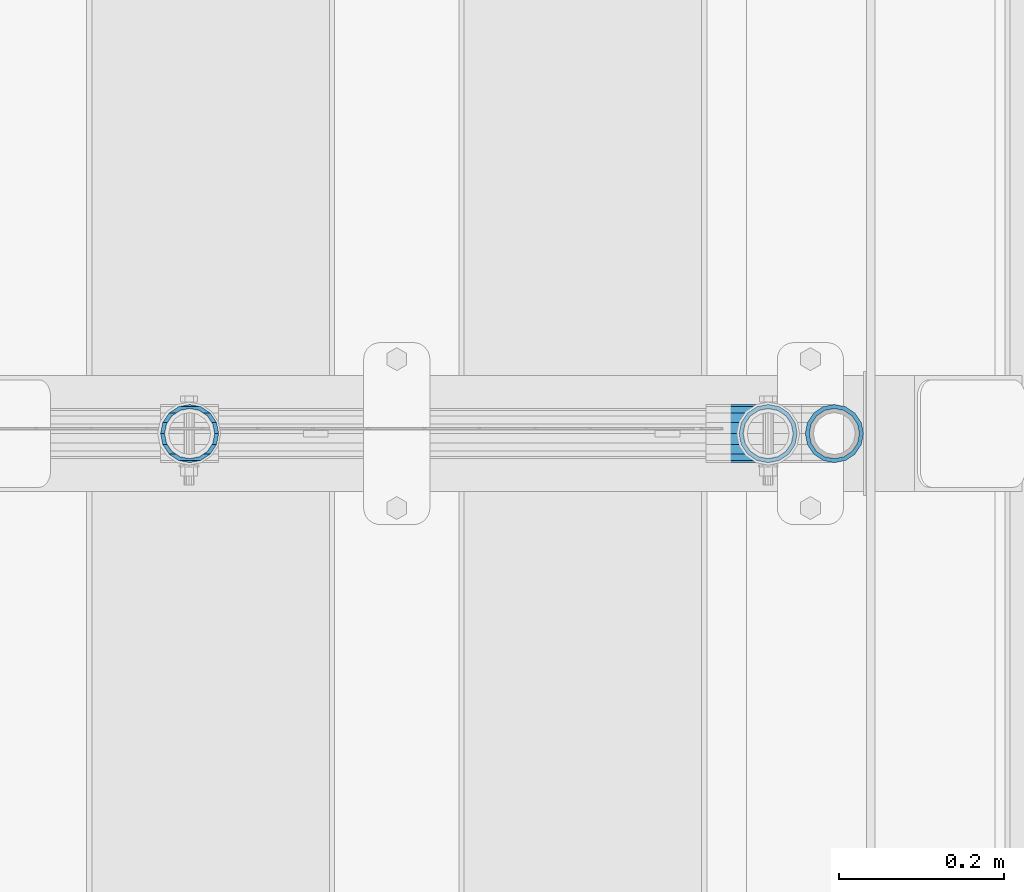
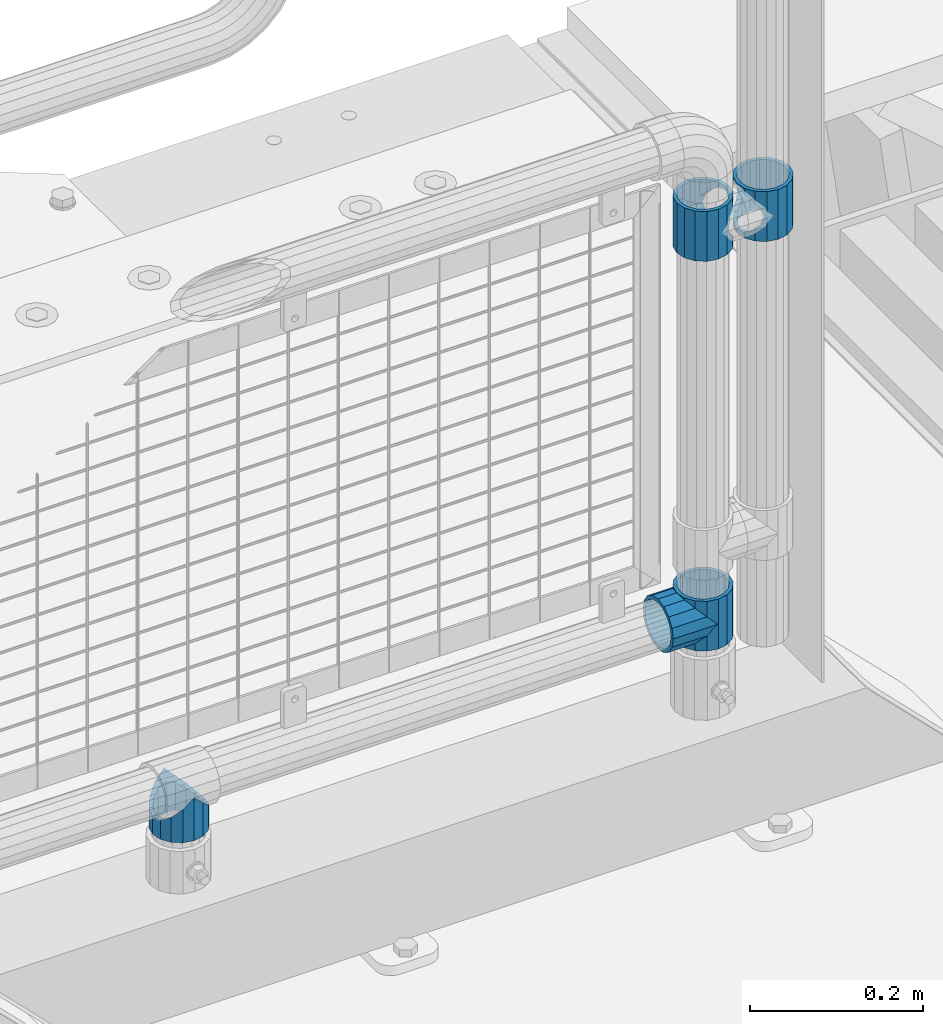
# One storey, part 188 of 270: 5 beams.
"""IFC2X3 building model written with IfcOpenShell, lengths in millimetres."""

import ifcopenshell
import ifcopenshell.guid

model = None  # the IFC model being written
_history = None  # IfcOwnerHistory: only IFC2X3 demands one
_inside = {}  # id of a spatial element -> (the spatial element, [elements in it])
_under = {}  # id of a project, library or spatial element -> (it, [spatial elements below it])
_declared = {}  # id of a project -> (the project, [libraries it declares])
_typed = {}  # id of a type object -> (the type object, [elements of that type])
_made_of = {}  # id of a material, layer set ... -> (it, [elements and type objects made of it])


def new_model(schema):
    """Start an empty IFC model of exactly this schema.

    Asked for "IFC4X3", IfcOpenShell would pick the latest addendum, in which some entities
    have other attributes; the version numbers below select the first issue.
    IFC2X3 requires an IfcOwnerHistory on every rooted entity: one is made here for all.
    """
    global model, _history
    if schema == "IFC4X3":
        model = ifcopenshell.file(schema_version=(4, 3, 0, 0))
    else:
        model = ifcopenshell.file(schema=schema)
    _inside.clear()
    _under.clear()
    _declared.clear()
    _typed.clear()
    _made_of.clear()
    _history = None
    if model.schema == "IFC2X3":
        org = make("IfcOrganization", Name="unknown")
        user = make(
            "IfcPersonAndOrganization",
            ThePerson=make("IfcPerson", FamilyName="unknown"),
            TheOrganization=org,
        )
        app = make(
            "IfcApplication",
            ApplicationDeveloper=org,
            Version="unknown",
            ApplicationFullName="unknown",
            ApplicationIdentifier="unknown",
        )
        _history = make(
            "IfcOwnerHistory",
            OwningUser=user,
            OwningApplication=app,
            ChangeAction="ADDED",
            CreationDate=0,
        )
    return model


def make(cls, **values):
    """One entity of the class cls with the attributes given. An attribute that is None is left unset."""
    return model.create_entity(
        cls, **{name: value for name, value in values.items() if value is not None}
    )


def rooted(cls, **values):
    """An entity with a GlobalId (a new one), such as an element, a storey or a relation."""
    return make(cls, GlobalId=ifcopenshell.guid.new(), OwnerHistory=_history, **values)


def si_unit(unit_type, name, prefix=None):
    """IfcSIUnit, for example si_unit("LENGTHUNIT", "METRE", prefix="MILLI")."""
    return make("IfcSIUnit", UnitType=unit_type, Prefix=prefix, Name=name)


def assignment(units):
    """IfcUnitAssignment: the units of a project."""
    return None if units is None else make("IfcUnitAssignment", Units=units)


def point(xyz):
    """IfcCartesianPoint."""
    return None if xyz is None else make("IfcCartesianPoint", Coordinates=xyz)


def direction(xyz):
    """IfcDirection."""
    return None if xyz is None else make("IfcDirection", DirectionRatios=xyz)


def frame(location, z_axis=None, x_axis=None):
    """IfcAxis2Placement3D, a coordinate frame: its origin and axes. An axis left out is left unset."""
    return make(
        "IfcAxis2Placement3D",
        Location=point(location),
        Axis=direction(z_axis),
        RefDirection=direction(x_axis),
    )


def origin_with_axes():
    """The frame at (0, 0, 0) with the z axis (0, 0, 1) and the x axis (1, 0, 0) written out."""
    return frame((0.0, 0.0, 0.0), z_axis=(0.0, 0.0, 1.0), x_axis=(1.0, 0.0, 0.0))


def place(relative_to, where):
    """IfcLocalPlacement: puts the frame where relative to a parent placement (None: the world)."""
    return make(
        "IfcLocalPlacement", PlacementRelTo=relative_to, RelativePlacement=where
    )


def context(
    kind, dimensions, precision=None, world=None, true_north=None, identifier=None
):
    """IfcGeometricRepresentationContext, for example the 3D "Model" context."""
    return make(
        "IfcGeometricRepresentationContext",
        ContextIdentifier=identifier,
        ContextType=kind,
        CoordinateSpaceDimension=dimensions,
        Precision=precision,
        WorldCoordinateSystem=world,
        TrueNorth=true_north,
    )


def subcontext(parent, identifier, kind, view, scale=None):
    """IfcGeometricRepresentationSubContext, for example "Body" below "Model"."""
    return make(
        "IfcGeometricRepresentationSubContext",
        ContextIdentifier=identifier,
        ContextType=kind,
        ParentContext=parent,
        TargetScale=scale,
        TargetView=view,
    )


def project(units=None, contexts=None):
    """IfcProject with its units and contexts."""
    return rooted(
        "IfcProject",
        Name="project",
        RepresentationContexts=contexts,
        UnitsInContext=assignment(units),
    )


def spatial(cls, under=None, at=None, **own):
    """A site, building, storey or space (cls), placed at a placement, below another one or the project."""
    s = rooted(cls, ObjectPlacement=at, **own)
    if under is not None:
        _under.setdefault(under.id(), (under, []))[1].append(s)
    return s


def faces_of(points, faces, orient=None, outer=None):
    """IfcFace entities. A face is a list of loops; a loop is a list of indices into points, from 0.

    orient and outer hold one flag for each loop. By default every Orientation is true, the
    first loop of a face is its IfcFaceOuterBound and the others are IfcFaceBound.
    """
    made = []
    for i, loops in enumerate(faces):
        bounds = []
        for j, loop in enumerate(loops):
            is_outer = j == 0 if outer is None else outer[i][j]
            bounds.append(
                make(
                    "IfcFaceOuterBound" if is_outer else "IfcFaceBound",
                    Bound=make("IfcPolyLoop", Polygon=[points[k] for k in loop]),
                    Orientation=True if orient is None else orient[i][j],
                )
            )
        made.append(make("IfcFace", Bounds=bounds))
    return made


def faceted_brep(points, faces, orient=None, outer=None, voids=None):
    """IfcFacetedBrep: a solid bounded by flat faces; with voids (closed shells), ...WithVoids."""
    shared = [point(p) for p in points]
    hull = make("IfcClosedShell", CfsFaces=faces_of(shared, faces, orient, outer))
    if voids is None:
        return make("IfcFacetedBrep", Outer=hull)
    return make(
        "IfcFacetedBrepWithVoids",
        Outer=hull,
        Voids=[
            make(cls, CfsFaces=faces_of(shared, fs, o, b)) for cls, fs, o, b in voids
        ],
    )


def shape(context_of_items, identifier, shape_type, items):
    """IfcShapeRepresentation: the items that make up one representation, for example the "Body"."""
    return make(
        "IfcShapeRepresentation",
        ContextOfItems=context_of_items,
        RepresentationIdentifier=identifier,
        RepresentationType=shape_type,
        Items=items,
    )


def material(Name=None, Category=None):
    """IfcMaterial."""
    return make("IfcMaterial", Name=Name, Category=Category)


def made_of(thing, what):
    """Note that an element or type object is made of a material, layer set ...; save() writes the relation."""
    if what is not None:
        _made_of.setdefault(what.id(), (what, []))[1].append(thing)
    return thing


def type_object(cls, material=None, **own):
    """A type object (cls), such as IfcWallType, which elements share."""
    return made_of(rooted(cls, **own), material)


def element(
    cls,
    number,
    at=None,
    inside=None,
    cuts=None,
    type_object=None,
    material=None,
    context=None,
    identifier="Body",
    shape_type=None,
    held_by="IfcProductDefinitionShape",
    body=None,
    shapes=None,
    **own,
):
    """One element of the class cls, such as IfcWall. Its Tag is "e" and its number.

    at: its placement. inside: the storey or other place that contains it. cuts: it is an
    opening in that element (IfcRelVoidsElement). A single representation is given by context,
    identifier, shape_type and body (its items); several are given by shapes. held_by: the class
    of the entity that holds the representations. save() writes the other relations.
    """
    e = rooted(cls, Tag="e%d" % number, ObjectPlacement=at, **own)
    if body is not None:
        shapes = [shape(context, identifier, shape_type, body)]
    if shapes is not None:
        e.Representation = make(held_by, Representations=shapes)
    if inside is not None:
        _inside.setdefault(inside.id(), (inside, []))[1].append(e)
    if cuts is not None:
        rooted(
            "IfcRelVoidsElement", RelatingBuildingElement=cuts, RelatedOpeningElement=e
        )
    if type_object is not None:
        _typed.setdefault(type_object.id(), (type_object, []))[1].append(e)
    return made_of(e, material)


def aggregate(whole, parts):
    """IfcRelAggregates: a whole, such as a stair, and the parts it consists of."""
    return rooted("IfcRelAggregates", RelatingObject=whole, RelatedObjects=parts)


def save(model, path):
    """Write the relations noted so far, then the file.

    IfcRelAggregates (storeys below a building ...), IfcRelContainedInSpatialStructure (elements
    in a storey), IfcRelDefinesByType, IfcRelAssociatesMaterial and IfcRelDeclares: one each for
    every whole, place, type object, material and project.
    """
    for whole, parts in _under.values():
        aggregate(whole, parts)
    for where, things in _inside.values():
        rooted(
            "IfcRelContainedInSpatialStructure",
            RelatedElements=things,
            RelatingStructure=where,
        )
    for kind, things in _typed.values():
        rooted("IfcRelDefinesByType", RelatedObjects=things, RelatingType=kind)
    for what, things in _made_of.values():
        rooted("IfcRelAssociatesMaterial", RelatedObjects=things, RelatingMaterial=what)
    for by, libraries in _declared.values():
        rooted("IfcRelDeclares", RelatingContext=by, RelatedDefinitions=libraries)
    model.write(path)


model = new_model("IFC2X3")

# Units and contexts
model_context = context("Model", 3, precision=1e-05, world=origin_with_axes())
body_context = subcontext(model_context, "Body", "Model", "MODEL_VIEW")
ifc_project = project(units=[si_unit("LENGTHUNIT", "METRE", prefix="MILLI"), si_unit("AREAUNIT", "SQUARE_METRE"), si_unit("VOLUMEUNIT", "CUBIC_METRE"), si_unit("MASSUNIT", "GRAM", prefix="KILO"), si_unit("TIMEUNIT", "SECOND"), si_unit("PLANEANGLEUNIT", "RADIAN"), si_unit("SOLIDANGLEUNIT", "STERADIAN"), si_unit("THERMODYNAMICTEMPERATUREUNIT", "DEGREE_CELSIUS"), si_unit("LUMINOUSINTENSITYUNIT", "LUMEN")], contexts=[model_context])

# Site, building, storey
site_placement = place(None, origin_with_axes())
site = spatial("IfcSite", under=ifc_project, at=site_placement, CompositionType="ELEMENT")
building_placement = place(site_placement, origin_with_axes())
building = spatial("IfcBuilding", under=site, at=building_placement, Name="Standard", CompositionType="ELEMENT")
storey_placement = place(building_placement, origin_with_axes())
storey = spatial("IfcBuildingStorey", under=building, at=storey_placement, Name="Undefined", CompositionType="ELEMENT", Elevation=0.0)

# Beams
ifc_material = material(Name="Misc_Undefined")
beam_type = type_object("IfcBeamType", PredefinedType="NOTDEFINED")
beam_1_placement = place(storey_placement, frame((19794.0, -16335.5, 883.82), z_axis=(-1.0, 0.0, 0.0), x_axis=(0.0, 0.0, -1.0)))
element("IfcBeam", 1, at=beam_1_placement, inside=storey, type_object=beam_type, material=ifc_material, context=body_context, shape_type="Brep", body=[
    faceted_brep([(7.11025618828319, -11.6144421722802, -32.8397438117172), (7.11025618828319, -11.6144421722802, -28.0397438117179), (13.689309190989, -21.4606908090118, -21.46069080901), (13.689309190989, -21.4606908090118, -27.1226768591041), (8.33762048232484, -13.4513226476338, -32.4743655677703), (23.5355578277203, -28.0397438117179, -11.614442172282), (23.5355578277203, -28.0397438117179, -20.0882031229885), (18.7689575919954, -24.8548033587067, -24.8548033587067), (35.1500000000015, -30.35, 0.0), (35.1500000000008, -30.3500000000004, -16.6306603983721), (46.7644421722812, -28.0397438117179, -11.614442172282), (46.7644421722812, -28.0397438117179, -20.0882031229885), (51.5310424080071, -24.8548033587067, -24.8548033587067), (56.6106908090125, -21.4606908090118, -21.46069080901), (56.6106908090125, -21.4606908090118, -27.1226768591041), (61.9623795176767, -13.4513226476338, -32.4743655677703), (63.1897438117183, -11.6144421722802, -28.0397438117179), (63.1897438117183, -11.6144421722802, -32.8397438117172), (65.5000000000008, 0.0, -30.3499999999985), (65.5000000000008, 0.0, -35.1500000000015), (63.1897438117183, 11.6144421722802, -28.0397438117179), (63.1897438117183, 11.6144421722802, -32.8397438117208), (56.6106908090125, 21.4606908090118, -21.46069080901), (56.6106908090125, 21.4606908090118, -27.1226768591005), (61.9623795176767, 13.4513226476338, -32.4743655677703), (46.7644421722812, 28.0397438117179, -11.614442172282), (46.7644421722812, 28.0397438117179, -20.0882031229812), (51.5310424080071, 24.8548033587067, -24.8548033587067), (35.1500000000015, 30.35, 0.0), (35.1500000000008, 30.3500000000004, -16.6306603983612), (23.5355578277203, 28.0397438117179, -11.614442172282), (23.5355578277203, 28.0397438117179, -20.0882031229812), (18.7689575919954, 24.8548033587067, -24.8548033587067), (13.689309190989, 21.4606908090118, -21.46069080901), (13.689309190989, 21.4606908090118, -27.1226768591005), (8.33762048232484, 13.4513226476338, -32.4743655677703), (7.11025618828324, 11.6144421722802, -28.0397438117179), (7.11025618828324, 11.6144421722802, -32.8397438117208), (4.80000000000075, 0.0, -30.3499999999985), (4.80000000000075, 0.0, -35.1500000000015), (0.0, 21.4606908090118, 21.46069080901), (0.0, 28.0397438117179, 11.614442172282), (70.2999999999993, 28.0397438117179, 11.614442172282), (70.2999999999993, 21.4606908090118, 21.46069080901), (0.0, 11.6144421722802, 28.0397438117179), (70.2999999999993, 11.6144421722802, 28.0397438117179), (0.0, 0.0, 30.3499999999985), (70.2999999999993, 0.0, 30.3499999999985), (0.0, -11.6144421722802, 28.0397438117179), (70.2999999999993, -11.6144421722802, 28.0397438117179), (0.0, -21.4606908090118, 21.46069080901), (70.2999999999993, -21.4606908090118, 21.46069080901), (0.0, -28.0397438117179, 11.614442172282), (70.2999999999993, -28.0397438117179, 11.614442172282), (0.0, -24.8548033587067, -24.8548033587067), (0.0, -13.4513226476338, -32.4743655677703), (0.0, 0.0, -35.1499999999996), (0.0, -32.4743655677721, 13.4513226476338), (0.0, -35.1499999999996, 0.0), (70.2999999999993, -35.1499999999996, 0.0), (70.2999999999993, -32.4743655677721, 13.4513226476338), (0.0, -24.8548033587067, 24.8548033587067), (70.2999999999993, -24.8548033587067, 24.8548033587067), (0.0, -13.4513226476338, 32.4743655677703), (70.2999999999993, -13.4513226476338, 32.4743655677703), (0.0, 0.0, 35.1499999999996), (70.2999999999993, 0.0, 35.1500000000015), (0.0, 13.4513226476338, 32.4743655677703), (70.2999999999993, 13.4513226476338, 32.4743655677703), (0.0, 24.8548033587067, 24.8548033587067), (70.2999999999993, 24.8548033587067, 24.8548033587067), (0.0, 32.4743655677721, 13.4513226476338), (70.2999999999993, 32.4743655677721, 13.4513226476338), (0.0, 35.1499999999996, 0.0), (70.2999999999993, 35.1499999999996, 0.0), (0.0, 32.4743655677721, -13.4513226476338), (70.2999999999993, 32.4743655677721, -13.4513226476338), (70.2999999999993, -13.4513226476338, -32.4743655677703), (70.2999999999993, -24.8548033587067, -24.8548033587067), (70.2999999999993, 0.0, -35.1500000000015), (70.2999999999993, 13.4513226476338, -32.4743655677703), (70.2999999999993, 24.8548033587067, -24.8548033587067), (0.0, 24.8548033587067, -24.8548033587067), (0.0, 13.4513226476338, -32.4743655677703), (70.2999999999993, -32.4743655677721, -13.4513226476338), (0.0, -32.4743655677721, -13.4513226476338), (0.0, -28.0397438117179, -11.614442172282), (0.0, -21.4606908090118, -21.46069080901), (0.0, -11.6144421722802, -28.0397438117179), (0.0, 0.0, -30.3499999999985), (0.0, 11.6144421722802, -28.0397438117179), (0.0, 21.4606908090118, -21.46069080901), (0.0, 28.0397438117179, -11.614442172282), (0.0, 30.3500000000004, 0.0), (0.0, -30.3500000000004, 0.0), (70.2999999999993, 30.3500000000004, 0.0), (70.2999999999993, 28.0397438117179, -11.614442172282), (70.2999999999993, 21.4606908090118, -21.46069080901), (70.2999999999993, 11.6144421722802, -28.0397438117179), (70.2999999999993, 0.0, -30.3499999999985), (70.2999999999993, -11.6144421722802, -28.0397438117179), (70.2999999999993, -21.4606908090118, -21.46069080901), (70.2999999999993, -28.0397438117179, -11.614442172282), (70.2999999999993, -30.3500000000004, 0.0)], [[[0, 1, 2, 3, 4]], [[3, 2, 5, 6, 7]], [[6, 5, 8, 9]], [[9, 8, 10, 11]], [[12, 11, 10, 13, 14]], [[15, 14, 13, 16, 17]], [[17, 16, 18, 19]], [[19, 18, 20, 21]], [[21, 20, 22, 23, 24]], [[23, 22, 25, 26, 27]], [[26, 25, 28, 29]], [[29, 28, 30, 31]], [[32, 31, 30, 33, 34]], [[35, 34, 33, 36, 37]], [[37, 36, 38, 39]], [[39, 38, 1, 0]], [[40, 41, 42, 43]], [[44, 40, 43, 45]], [[46, 44, 45, 47]], [[48, 46, 47, 49]], [[50, 48, 49, 51]], [[52, 50, 51, 53]], [[7, 54, 55, 4, 3]], [[4, 55, 56, 39, 0]], [[57, 58, 59, 60]], [[61, 57, 60, 62]], [[63, 61, 62, 64]], [[65, 63, 64, 66]], [[67, 65, 66, 68]], [[69, 67, 68, 70]], [[71, 69, 70, 72]], [[73, 71, 72, 74]], [[75, 73, 74, 76]], [[77, 78, 12, 14, 15]], [[79, 77, 15, 17, 19]], [[24, 80, 79, 19, 21]], [[27, 81, 80, 24, 23]], [[82, 75, 76, 81, 27, 26, 29, 31, 32]], [[83, 82, 32, 34, 35]], [[56, 83, 35, 37, 39]], [[9, 11, 12, 78, 84, 85, 54, 7, 6]], [[58, 85, 84, 59]], [[57, 61, 63, 65, 67, 69, 71, 73, 75, 82, 83, 56, 55, 54, 85, 58], [86, 87, 88, 89, 90, 91, 92, 93, 41, 40, 44, 46, 48, 50, 52, 94]], [[90, 89, 38, 36]], [[91, 90, 36, 33]], [[92, 91, 33, 30]], [[93, 92, 30, 28]], [[41, 93, 28, 95, 42]], [[96, 95, 28, 25]], [[97, 96, 25, 22]], [[98, 97, 22, 20]], [[99, 98, 20, 18]], [[100, 99, 18, 16]], [[101, 100, 16, 13]], [[102, 101, 13, 10]], [[103, 102, 10, 8]], [[78, 77, 79, 80, 81, 76, 74, 72, 70, 68, 66, 64, 62, 60, 59, 84], [51, 49, 47, 45, 43, 42, 95, 96, 97, 98, 99, 100, 101, 102, 103, 53]], [[8, 94, 52, 53, 103]], [[86, 94, 8, 5]], [[87, 86, 5, 2]], [[88, 87, 2, 1]], [[89, 88, 1, 38]]]),
])
beam_2_placement = place(storey_placement, frame((19874.0, -16335.5, 883.82), z_axis=(1.0, 0.0, 0.0), x_axis=(0.0, 0.0, -1.0)))
element("IfcBeam", 2, at=beam_2_placement, inside=storey, type_object=beam_type, material=ifc_material, context=body_context, shape_type="Brep", body=[
    faceted_brep([(56.6106908090125, 21.4606908090118, -27.1226768591005), (56.6106908090125, 21.4606908090118, -21.46069080901), (46.7644421722812, 28.0397438117179, -11.614442172282), (46.7644421722812, 28.0397438117179, -20.0882031229812), (51.5310424080071, 24.8548033587067, -24.8548033587067), (63.1897438117183, 11.6144421722802, -32.8397438117208), (63.1897438117183, 11.6144421722802, -28.0397438117179), (61.9623795176767, 13.4513226476338, -32.4743655677703), (65.5000000000008, 0.0, -35.1500000000015), (65.5000000000008, 0.0, -30.3499999999985), (63.1897438117183, -11.6144421722802, -32.8397438117172), (63.1897438117183, -11.6144421722802, -28.0397438117179), (61.9623795176767, -13.4513226476338, -32.4743655677703), (56.6106908090125, -21.4606908090118, -27.1226768591041), (56.6106908090125, -21.4606908090118, -21.46069080901), (51.5310424080071, -24.8548033587067, -24.8548033587067), (46.7644421722812, -28.0397438117179, -20.0882031229885), (46.7644421722812, -28.0397438117179, -11.614442172282), (35.1500000000008, -30.3500000000004, -16.6306603983721), (35.1500000000015, -30.35, 0.0), (23.5355578277203, -28.0397438117179, -20.0882031229885), (23.5355578277203, -28.0397438117179, -11.614442172282), (13.689309190989, -21.4606908090118, -27.1226768591041), (13.689309190989, -21.4606908090118, -21.46069080901), (18.7689575919954, -24.8548033587067, -24.8548033587067), (7.11025618828319, -11.6144421722802, -32.8397438117172), (7.11025618828319, -11.6144421722802, -28.0397438117179), (8.33762048232484, -13.4513226476338, -32.4743655677703), (4.80000000000075, 0.0, -35.1500000000015), (4.80000000000075, 0.0, -30.3499999999985), (7.11025618828324, 11.6144421722802, -32.8397438117208), (7.11025618828324, 11.6144421722802, -28.0397438117179), (8.33762048232484, 13.4513226476338, -32.4743655677703), (13.689309190989, 21.4606908090118, -27.1226768591005), (13.689309190989, 21.4606908090118, -21.46069080901), (18.7689575919954, 24.8548033587067, -24.8548033587067), (23.5355578277203, 28.0397438117179, -20.0882031229812), (23.5355578277203, 28.0397438117179, -11.614442172282), (35.1500000000008, 30.3500000000004, -16.6306603983612), (35.1500000000015, 30.35, 0.0), (0.0, 32.4743655677721, -13.4513226476338), (0.0, 35.1499999999996, 0.0), (70.2999999999993, 35.1499999999996, 0.0), (70.2999999999993, 32.4743655677721, -13.4513226476338), (0.0, 32.4743655677721, 13.4513226476338), (70.2999999999993, 32.4743655677721, 13.4513226476338), (0.0, 24.8548033587067, 24.8548033587067), (70.2999999999993, 24.8548033587067, 24.8548033587067), (0.0, 13.4513226476338, 32.4743655677703), (70.2999999999993, 13.4513226476338, 32.4743655677703), (0.0, 0.0, 35.1499999999996), (70.2999999999993, 0.0, 35.1500000000015), (0.0, -13.4513226476338, 32.4743655677703), (70.2999999999993, -13.4513226476338, 32.4743655677703), (0.0, -24.8548033587067, 24.8548033587067), (70.2999999999993, -24.8548033587067, 24.8548033587067), (0.0, -32.4743655677721, 13.4513226476338), (70.2999999999993, -32.4743655677721, 13.4513226476338), (0.0, -35.1499999999996, 0.0), (70.2999999999993, -35.1499999999996, 0.0), (70.2999999999993, -30.3500000000004, 0.0), (70.2999999999993, -28.0397438117179, -11.614442172282), (70.2999999999993, -21.4606908090118, -21.46069080901), (70.2999999999993, -11.6144421722802, -28.0397438117179), (70.2999999999993, 0.0, -30.3499999999985), (70.2999999999993, 11.6144421722802, -28.0397438117179), (70.2999999999993, 21.4606908090118, -21.46069080901), (70.2999999999993, 28.0397438117179, -11.614442172282), (0.0, -28.0397438117179, -11.614442172282), (0.0, -30.3500000000004, 0.0), (0.0, -21.4606908090118, -21.46069080901), (0.0, -11.6144421722802, -28.0397438117179), (0.0, 0.0, -30.3499999999985), (0.0, 11.6144421722802, -28.0397438117179), (0.0, 21.4606908090118, -21.46069080901), (0.0, 28.0397438117179, -11.614442172282), (0.0, 30.3500000000004, 0.0), (70.2999999999993, 30.3500000000004, 0.0), (0.0, 28.0397438117179, 11.614442172282), (70.2999999999993, 28.0397438117179, 11.614442172282), (0.0, 21.4606908090118, 21.46069080901), (70.2999999999993, 21.4606908090118, 21.46069080901), (0.0, 11.6144421722802, 28.0397438117179), (70.2999999999993, 11.6144421722802, 28.0397438117179), (0.0, 0.0, 30.3499999999985), (70.2999999999993, 0.0, 30.3499999999985), (0.0, -11.6144421722802, 28.0397438117179), (70.2999999999993, -11.6144421722802, 28.0397438117179), (0.0, -21.4606908090118, 21.46069080901), (70.2999999999993, -21.4606908090118, 21.46069080901), (0.0, -28.0397438117179, 11.614442172282), (70.2999999999993, -28.0397438117179, 11.614442172282), (70.2999999999993, -24.8548033587067, -24.8548033587067), (70.2999999999993, -13.4513226476338, -32.4743655677703), (70.2999999999993, 0.0, -35.1500000000015), (70.2999999999993, 13.4513226476338, -32.4743655677703), (70.2999999999993, 24.8548033587067, -24.8548033587067), (70.2999999999993, -32.4743655677721, -13.4513226476338), (0.0, -32.4743655677721, -13.4513226476338), (0.0, 24.8548033587067, -24.8548033587067), (0.0, 13.4513226476338, -32.4743655677703), (0.0, 0.0, -35.1499999999996), (0.0, -13.4513226476338, -32.4743655677703), (0.0, -24.8548033587067, -24.8548033587067)], [[[0, 1, 2, 3, 4]], [[5, 6, 1, 0, 7]], [[8, 9, 6, 5]], [[10, 11, 9, 8]], [[12, 13, 14, 11, 10]], [[15, 16, 17, 14, 13]], [[18, 19, 17, 16]], [[20, 21, 19, 18]], [[22, 23, 21, 20, 24]], [[25, 26, 23, 22, 27]], [[28, 29, 26, 25]], [[30, 31, 29, 28]], [[32, 33, 34, 31, 30]], [[35, 36, 37, 34, 33]], [[38, 39, 37, 36]], [[3, 2, 39, 38]], [[40, 41, 42, 43]], [[41, 44, 45, 42]], [[44, 46, 47, 45]], [[46, 48, 49, 47]], [[48, 50, 51, 49]], [[50, 52, 53, 51]], [[52, 54, 55, 53]], [[54, 56, 57, 55]], [[56, 58, 59, 57]], [[60, 61, 17, 19]], [[61, 62, 14, 17]], [[62, 63, 11, 14]], [[63, 64, 9, 11]], [[64, 65, 6, 9]], [[65, 66, 1, 6]], [[66, 67, 2, 1]], [[68, 69, 19, 21]], [[70, 68, 21, 23]], [[71, 70, 23, 26]], [[72, 71, 26, 29]], [[73, 72, 29, 31]], [[74, 73, 31, 34]], [[75, 74, 34, 37]], [[76, 75, 37, 39]], [[67, 77, 39, 2]], [[78, 76, 39, 77, 79]], [[80, 78, 79, 81]], [[82, 80, 81, 83]], [[84, 82, 83, 85]], [[86, 84, 85, 87]], [[88, 86, 87, 89]], [[90, 88, 89, 91]], [[19, 69, 90, 91, 60]], [[92, 93, 94, 95, 96, 43, 42, 45, 47, 49, 51, 53, 55, 57, 59, 97], [89, 87, 85, 83, 81, 79, 77, 67, 66, 65, 64, 63, 62, 61, 60, 91]], [[58, 98, 97, 59]], [[56, 54, 52, 50, 48, 46, 44, 41, 40, 99, 100, 101, 102, 103, 98, 58], [68, 70, 71, 72, 73, 74, 75, 76, 78, 80, 82, 84, 86, 88, 90, 69]], [[100, 99, 35, 33, 32]], [[101, 100, 32, 30, 28]], [[27, 102, 101, 28, 25]], [[24, 103, 102, 27, 22]], [[18, 16, 15, 92, 97, 98, 103, 24, 20]], [[93, 92, 15, 13, 12]], [[94, 93, 12, 10, 8]], [[7, 95, 94, 8, 5]], [[4, 96, 95, 7, 0]], [[99, 40, 43, 96, 4, 3, 38, 36, 35]]]),
])
beam_3_placement = place(storey_placement, frame((19794.0, -16335.5, 298.670000000001), z_axis=(0.0, 1.0, 0.0), x_axis=(-1.0, 0.0, 0.0)))
element("IfcBeam", 3, at=beam_3_placement, inside=storey, type_object=beam_type, material=ifc_material, context=body_context, shape_type="Brep", body=[
    faceted_brep([(0.0, 0.0, -35.1499999999996), (13.4513226476338, -13.4513226476329, -32.4743655677721), (13.4513226476338, 13.4513226476329, -32.4743655677721), (32.4743655677703, -26.8123795176775, 13.4513226476338), (32.4743655677703, -32.4743655677717, 13.4513226476338), (24.8548033587067, -24.8548033587072, 24.8548033587067), (24.8548033587067, -16.3810424080045, 24.8548033587067), (27.1226768591041, -21.4606908090117, 21.4606908090118), (35.1500000000015, -30.35, 0.0), (35.1500000000015, -35.15, 0.0), (32.8397438117208, -28.0397438117175, 11.6144421722802), (32.8397438117172, -28.0397438117175, -11.6144421722802), (32.4743655677703, -26.8123795176776, -13.4513226476338), (32.4743655677703, -32.4743655677717, -13.4513226476338), (27.1226768591041, -21.4606908090117, -21.4606908090118), (24.8548033587067, -16.3810424080045, -24.8548033587067), (24.8548033587067, -24.8548033587072, -24.8548033587067), (20.0882031229849, -11.6144421722805, -28.0397438117179), (16.6306603983721, 0.0, -30.3500000000004), (20.0882031229849, 11.6144421722805, -28.0397438117179), (24.8548033587067, 16.3810424080045, -24.8548033587067), (24.8548033587067, 24.8548033587072, -24.8548033587067), (27.1226768591041, 21.4606908090117, -21.4606908090118), (32.4743655677703, 26.8123795176775, -13.4513226476338), (32.4743655677703, 32.4743655677717, -13.4513226476338), (32.8397438117172, 28.0397438117175, -11.6144421722802), (35.1500000000015, 30.35, 0.0), (35.1500000000015, 35.1500000000003, 0.0), (32.8397438117208, 28.0397438117175, 11.6144421722802), (32.4743655677703, 26.8123795176776, 13.4513226476338), (32.4743655677703, 32.4743655677717, 13.4513226476338), (27.1226768591041, 21.4606908090117, 21.4606908090118), (24.8548033587067, 16.3810424080045, 24.8548033587067), (24.8548033587067, 24.8548033587072, 24.8548033587067), (13.4513226476338, 13.4513226476329, 32.4743655677721), (13.4513226476338, -13.4513226476329, 32.4743655677721), (0.0, 0.0, 35.1499999999996), (20.0882031229812, 11.6144421722805, 28.0397438117179), (16.6306603983612, 0.0, 30.3500000000004), (20.0882031229812, -11.6144421722805, 28.0397438117179), (60.1500000000015, -35.15, 0.0), (60.1500000000015, -32.4743655677717, 13.4513226476338), (60.1500000000015, -24.8548033587072, 24.8548033587067), (60.1500000000015, -13.4513226476329, 32.4743655677721), (60.1499999999978, 0.0, 35.1499999999996), (60.1500000000015, -24.8548033587072, -24.8548033587067), (60.1500000000015, -32.4743655677717, -13.4513226476338), (60.1500000000015, -13.4513226476329, -32.4743655677721), (60.1499999999978, 0.0, -35.1499999999996), (60.1500000000015, 13.4513226476329, -32.4743655677721), (60.1500000000015, 24.8548033587072, -24.8548033587067), (60.1500000000015, 32.4743655677717, -13.4513226476338), (60.1500000000015, 35.15, 0.0), (60.1500000000015, 32.4743655677717, 13.4513226476338), (60.1500000000015, 24.8548033587072, 24.8548033587067), (60.1500000000015, 13.4513226476329, 32.4743655677721), (60.1500000000015, -21.4606908090117, 21.4606908090118), (60.1500000000015, -11.6144421722805, 28.0397438117179), (60.1500000000015, 0.0, 30.3500000000004), (60.1500000000015, 11.6144421722805, 28.0397438117179), (60.1500000000015, 21.4606908090117, 21.4606908090118), (60.1500000000015, 28.0397438117175, 11.6144421722802), (60.1500000000015, 30.35, 0.0), (60.1500000000015, 28.0397438117175, -11.6144421722802), (60.1500000000015, 21.4606908090117, -21.4606908090118), (60.1500000000015, 11.6144421722805, -28.0397438117179), (60.1500000000015, 0.0, -30.3500000000004), (60.1500000000015, -11.6144421722805, -28.0397438117179), (60.1500000000015, -21.4606908090117, -21.4606908090118), (60.1500000000015, -28.0397438117175, -11.6144421722802), (60.1500000000015, -30.35, 0.0), (60.1500000000015, -28.0397438117175, 11.6144421722802)], [[[0, 1, 2]], [[3, 4, 5, 6, 7]], [[8, 9, 4, 3, 10]], [[11, 12, 13, 9, 8]], [[14, 15, 16, 13, 12]], [[2, 1, 16, 15, 17, 18, 19, 20, 21]], [[21, 20, 22, 23, 24]], [[24, 23, 25, 26, 27]], [[27, 26, 28, 29, 30]], [[30, 29, 31, 32, 33]], [[34, 35, 36]], [[33, 32, 37, 38, 39, 6, 5, 35, 34]], [[40, 41, 4, 9]], [[41, 42, 5, 4]], [[42, 43, 35, 5]], [[43, 44, 36, 35]], [[45, 46, 13, 16]], [[47, 45, 16, 1]], [[48, 47, 1, 0]], [[49, 48, 0, 2]], [[50, 49, 2, 21]], [[51, 50, 21, 24]], [[52, 51, 24, 27]], [[53, 52, 27, 30]], [[54, 53, 30, 33]], [[55, 54, 33, 34]], [[44, 55, 34, 36]], [[46, 40, 9, 13]], [[45, 47, 48, 49, 50, 51, 52, 53, 54, 55, 44, 43, 42, 41, 40, 46], [56, 57, 58, 59, 60, 61, 62, 63, 64, 65, 66, 67, 68, 69, 70, 71]], [[59, 58, 38, 37]], [[60, 59, 37, 32, 31]], [[61, 60, 31, 29, 28]], [[62, 61, 28, 26]], [[63, 62, 26, 25]], [[22, 64, 63, 25, 23]], [[19, 65, 64, 22, 20]], [[66, 65, 19, 18]], [[67, 66, 18, 17]], [[68, 67, 17, 15, 14]], [[69, 68, 14, 12, 11]], [[70, 69, 11, 8]], [[71, 70, 8, 10]], [[7, 56, 71, 10, 3]], [[39, 57, 56, 7, 6]], [[58, 57, 39, 38]]]),
])
beam_4_placement = place(storey_placement, frame((19794.0, -16335.5, 333.820000000001), z_axis=(1.0, 0.0, 0.0), x_axis=(0.0, 0.0, -1.0)))
element("IfcBeam", 4, at=beam_4_placement, inside=storey, type_object=beam_type, material=ifc_material, context=body_context, shape_type="Brep", body=[
    faceted_brep([(56.6106908090125, 21.4606908090118, -27.1226768591005), (56.6106908090125, 21.4606908090118, -21.46069080901), (46.7644421722812, 28.0397438117179, -11.614442172282), (46.7644421722812, 28.0397438117179, -20.0882031229812), (51.5310424080071, 24.8548033587067, -24.8548033587067), (63.1897438117183, 11.6144421722802, -32.8397438117208), (63.1897438117183, 11.6144421722802, -28.0397438117179), (61.9623795176767, 13.4513226476338, -32.4743655677703), (65.5000000000008, 0.0, -35.1500000000015), (65.5000000000008, 0.0, -30.3499999999985), (63.1897438117183, -11.6144421722802, -32.8397438117172), (63.1897438117183, -11.6144421722802, -28.0397438117179), (61.9623795176767, -13.4513226476338, -32.4743655677703), (56.6106908090125, -21.4606908090118, -27.1226768591041), (56.6106908090125, -21.4606908090118, -21.46069080901), (51.5310424080071, -24.8548033587067, -24.8548033587067), (46.7644421722812, -28.0397438117179, -20.0882031229885), (46.7644421722812, -28.0397438117179, -11.614442172282), (35.1500000000008, -30.3500000000004, -16.6306603983721), (35.1500000000015, -30.35, 0.0), (23.5355578277203, -28.0397438117179, -20.0882031229885), (23.5355578277203, -28.0397438117179, -11.614442172282), (13.689309190989, -21.4606908090118, -27.1226768591041), (13.689309190989, -21.4606908090118, -21.46069080901), (18.7689575919954, -24.8548033587067, -24.8548033587067), (7.11025618828319, -11.6144421722802, -32.8397438117172), (7.11025618828319, -11.6144421722802, -28.0397438117179), (8.33762048232484, -13.4513226476338, -32.4743655677703), (4.80000000000075, 0.0, -35.1500000000015), (4.80000000000075, 0.0, -30.3499999999985), (7.11025618828324, 11.6144421722802, -32.8397438117208), (7.11025618828324, 11.6144421722802, -28.0397438117179), (8.33762048232484, 13.4513226476338, -32.4743655677703), (13.689309190989, 21.4606908090118, -27.1226768591005), (13.689309190989, 21.4606908090118, -21.46069080901), (18.7689575919954, 24.8548033587067, -24.8548033587067), (23.5355578277203, 28.0397438117179, -20.0882031229812), (23.5355578277203, 28.0397438117179, -11.614442172282), (35.1500000000008, 30.3500000000004, -16.6306603983612), (35.1500000000015, 30.35, 0.0), (0.0, 32.4743655677721, -13.4513226476338), (0.0, 35.1499999999996, 0.0), (70.2999999999993, 35.1499999999996, 0.0), (70.2999999999993, 32.4743655677721, -13.4513226476338), (0.0, 32.4743655677721, 13.4513226476338), (70.2999999999993, 32.4743655677721, 13.4513226476338), (0.0, 24.8548033587067, 24.8548033587067), (70.2999999999993, 24.8548033587067, 24.8548033587067), (0.0, 13.4513226476338, 32.4743655677703), (70.2999999999993, 13.4513226476338, 32.4743655677703), (0.0, 0.0, 35.1499999999996), (70.2999999999993, 0.0, 35.1500000000015), (0.0, -13.4513226476338, 32.4743655677703), (70.2999999999993, -13.4513226476338, 32.4743655677703), (0.0, -24.8548033587067, 24.8548033587067), (70.2999999999993, -24.8548033587067, 24.8548033587067), (0.0, -32.4743655677721, 13.4513226476338), (70.2999999999993, -32.4743655677721, 13.4513226476338), (0.0, -35.1499999999996, 0.0), (70.2999999999993, -35.1499999999996, 0.0), (70.2999999999993, -30.3500000000004, 0.0), (70.2999999999993, -28.0397438117179, -11.614442172282), (70.2999999999993, -21.4606908090118, -21.46069080901), (70.2999999999993, -11.6144421722802, -28.0397438117179), (70.2999999999993, 0.0, -30.3499999999985), (70.2999999999993, 11.6144421722802, -28.0397438117179), (70.2999999999993, 21.4606908090118, -21.46069080901), (70.2999999999993, 28.0397438117179, -11.614442172282), (0.0, -28.0397438117179, -11.614442172282), (0.0, -30.3500000000004, 0.0), (0.0, -21.4606908090118, -21.46069080901), (0.0, -11.6144421722802, -28.0397438117179), (0.0, 0.0, -30.3499999999985), (0.0, 11.6144421722802, -28.0397438117179), (0.0, 21.4606908090118, -21.46069080901), (0.0, 28.0397438117179, -11.614442172282), (0.0, 30.3500000000004, 0.0), (70.2999999999993, 30.3500000000004, 0.0), (0.0, 28.0397438117179, 11.614442172282), (70.2999999999993, 28.0397438117179, 11.614442172282), (0.0, 21.4606908090118, 21.46069080901), (70.2999999999993, 21.4606908090118, 21.46069080901), (0.0, 11.6144421722802, 28.0397438117179), (70.2999999999993, 11.6144421722802, 28.0397438117179), (0.0, 0.0, 30.3499999999985), (70.2999999999993, 0.0, 30.3499999999985), (0.0, -11.6144421722802, 28.0397438117179), (70.2999999999993, -11.6144421722802, 28.0397438117179), (0.0, -21.4606908090118, 21.46069080901), (70.2999999999993, -21.4606908090118, 21.46069080901), (0.0, -28.0397438117179, 11.614442172282), (70.2999999999993, -28.0397438117179, 11.614442172282), (70.2999999999993, -24.8548033587067, -24.8548033587067), (70.2999999999993, -13.4513226476338, -32.4743655677703), (70.2999999999993, 0.0, -35.1500000000015), (70.2999999999993, 13.4513226476338, -32.4743655677703), (70.2999999999993, 24.8548033587067, -24.8548033587067), (70.2999999999993, -32.4743655677721, -13.4513226476338), (0.0, -32.4743655677721, -13.4513226476338), (0.0, 24.8548033587067, -24.8548033587067), (0.0, 13.4513226476338, -32.4743655677703), (0.0, 0.0, -35.1499999999996), (0.0, -13.4513226476338, -32.4743655677703), (0.0, -24.8548033587067, -24.8548033587067)], [[[0, 1, 2, 3, 4]], [[5, 6, 1, 0, 7]], [[8, 9, 6, 5]], [[10, 11, 9, 8]], [[12, 13, 14, 11, 10]], [[15, 16, 17, 14, 13]], [[18, 19, 17, 16]], [[20, 21, 19, 18]], [[22, 23, 21, 20, 24]], [[25, 26, 23, 22, 27]], [[28, 29, 26, 25]], [[30, 31, 29, 28]], [[32, 33, 34, 31, 30]], [[35, 36, 37, 34, 33]], [[38, 39, 37, 36]], [[3, 2, 39, 38]], [[40, 41, 42, 43]], [[41, 44, 45, 42]], [[44, 46, 47, 45]], [[46, 48, 49, 47]], [[48, 50, 51, 49]], [[50, 52, 53, 51]], [[52, 54, 55, 53]], [[54, 56, 57, 55]], [[56, 58, 59, 57]], [[60, 61, 17, 19]], [[61, 62, 14, 17]], [[62, 63, 11, 14]], [[63, 64, 9, 11]], [[64, 65, 6, 9]], [[65, 66, 1, 6]], [[66, 67, 2, 1]], [[68, 69, 19, 21]], [[70, 68, 21, 23]], [[71, 70, 23, 26]], [[72, 71, 26, 29]], [[73, 72, 29, 31]], [[74, 73, 31, 34]], [[75, 74, 34, 37]], [[76, 75, 37, 39]], [[67, 77, 39, 2]], [[78, 76, 39, 77, 79]], [[80, 78, 79, 81]], [[82, 80, 81, 83]], [[84, 82, 83, 85]], [[86, 84, 85, 87]], [[88, 86, 87, 89]], [[90, 88, 89, 91]], [[19, 69, 90, 91, 60]], [[92, 93, 94, 95, 96, 43, 42, 45, 47, 49, 51, 53, 55, 57, 59, 97], [89, 87, 85, 83, 81, 79, 77, 67, 66, 65, 64, 63, 62, 61, 60, 91]], [[58, 98, 97, 59]], [[56, 54, 52, 50, 48, 46, 44, 41, 40, 99, 100, 101, 102, 103, 98, 58], [68, 70, 71, 72, 73, 74, 75, 76, 78, 80, 82, 84, 86, 88, 90, 69]], [[100, 99, 35, 33, 32]], [[101, 100, 32, 30, 28]], [[27, 102, 101, 28, 25]], [[24, 103, 102, 27, 22]], [[18, 16, 15, 92, 97, 98, 103, 24, 20]], [[93, 92, 15, 13, 12]], [[94, 93, 12, 10, 8]], [[7, 95, 94, 8, 5]], [[4, 96, 95, 7, 0]], [[99, 40, 43, 96, 4, 3, 38, 36, 35]]]),
])
beam_5_placement = place(storey_placement, frame((19094.61, -16335.5, 298.169999999999), z_axis=(0.0, 1.0, 0.0), x_axis=(0.0, 0.0, -1.0)))
element("IfcBeam", 5, at=beam_5_placement, inside=storey, type_object=beam_type, material=ifc_material, context=body_context, shape_type="Brep", body=[
    faceted_brep([(13.4513226476338, 13.4513226476329, 32.4743655677721), (13.4513226476338, -13.4513226476329, 32.4743655677721), (0.0, 0.0, 35.1499999999996), (27.1226768591041, -21.4606908090117, -21.4606908090118), (24.8548033587067, -16.3810424080045, -24.8548033587067), (24.8548033587067, -24.8548033587072, -24.8548033587067), (32.4743655677703, -32.4743655677717, -13.4513226476338), (32.4743655677703, -26.8123795176776, -13.4513226476338), (0.0, 0.0, -35.1499999999996), (13.4513226476338, -13.4513226476329, -32.4743655677721), (13.4513226476338, 13.4513226476329, -32.4743655677721), (20.0882031229849, -11.6144421722805, -28.0397438117179), (16.6306603983721, 0.0, -30.3500000000004), (20.0882031229849, 11.6144421722805, -28.0397438117179), (24.8548033587067, 16.3810424080045, -24.8548033587067), (24.8548033587067, 24.8548033587072, -24.8548033587067), (27.1226768591041, 21.4606908090117, -21.4606908090118), (32.4743655677703, 26.8123795176775, -13.4513226476338), (32.4743655677703, 32.4743655677717, -13.4513226476338), (32.8397438117172, 28.0397438117175, -11.6144421722802), (35.1500000000015, 30.35, 0.0), (35.1500000000015, 35.1500000000003, 0.0), (32.8397438117208, 28.0397438117175, 11.6144421722802), (32.4743655677703, 26.8123795176776, 13.4513226476338), (32.4743655677703, 32.4743655677717, 13.4513226476338), (27.1226768591041, 21.4606908090117, 21.4606908090118), (24.8548033587067, 16.3810424080045, 24.8548033587067), (24.8548033587067, 24.8548033587072, 24.8548033587067), (20.0882031229812, 11.6144421722805, 28.0397438117179), (16.6306603983612, 0.0, 30.3500000000004), (20.0882031229812, -11.6144421722805, 28.0397438117179), (24.8548033587067, -16.3810424080045, 24.8548033587067), (24.8548033587067, -24.8548033587072, 24.8548033587067), (32.4743655677703, -26.8123795176775, 13.4513226476338), (32.4743655677703, -32.4743655677717, 13.4513226476338), (27.1226768591041, -21.4606908090117, 21.4606908090118), (35.1500000000015, -30.35, 0.0), (35.1500000000015, -35.15, 0.0), (32.8397438117208, -28.0397438117175, 11.6144421722802), (32.8397438117172, -28.0397438117175, -11.6144421722802), (60.1500000000015, -24.8548033587072, -24.8548033587067), (60.1500000000015, -32.4743655677717, -13.4513226476338), (60.1500000000015, -13.4513226476329, -32.4743655677721), (60.1499999999978, 0.0, -35.1499999999996), (60.1500000000015, 13.4513226476329, -32.4743655677721), (60.1500000000015, 24.8548033587072, -24.8548033587067), (60.1500000000015, 32.4743655677717, -13.4513226476338), (60.1500000000015, 35.15, 0.0), (60.1500000000015, 32.4743655677717, 13.4513226476338), (60.1500000000015, 24.8548033587072, 24.8548033587067), (60.1500000000015, 13.4513226476329, 32.4743655677721), (60.1499999999978, 0.0, 35.1499999999996), (60.1500000000015, -13.4513226476329, 32.4743655677721), (60.1500000000015, -24.8548033587072, 24.8548033587067), (60.1500000000015, -32.4743655677717, 13.4513226476338), (60.1500000000015, -35.15, 0.0), (60.1500000000015, -21.4606908090117, 21.4606908090118), (60.1500000000015, -11.6144421722805, 28.0397438117179), (60.1500000000015, 0.0, 30.3500000000004), (60.1500000000015, 11.6144421722805, 28.0397438117179), (60.1500000000015, 21.4606908090117, 21.4606908090118), (60.1500000000015, 28.0397438117175, 11.6144421722802), (60.1500000000015, 30.35, 0.0), (60.1500000000015, 28.0397438117175, -11.6144421722802), (60.1500000000015, 21.4606908090117, -21.4606908090118), (60.1500000000015, 11.6144421722805, -28.0397438117179), (60.1500000000015, 0.0, -30.3500000000004), (60.1500000000015, -11.6144421722805, -28.0397438117179), (60.1500000000015, -21.4606908090117, -21.4606908090118), (60.1500000000015, -28.0397438117175, -11.6144421722802), (60.1500000000015, -30.35, 0.0), (60.1500000000015, -28.0397438117175, 11.6144421722802)], [[[0, 1, 2]], [[3, 4, 5, 6, 7]], [[8, 9, 10]], [[10, 9, 5, 4, 11, 12, 13, 14, 15]], [[15, 14, 16, 17, 18]], [[18, 17, 19, 20, 21]], [[21, 20, 22, 23, 24]], [[24, 23, 25, 26, 27]], [[27, 26, 28, 29, 30, 31, 32, 1, 0]], [[33, 34, 32, 31, 35]], [[36, 37, 34, 33, 38]], [[39, 7, 6, 37, 36]], [[40, 41, 6, 5]], [[42, 40, 5, 9]], [[43, 42, 9, 8]], [[44, 43, 8, 10]], [[45, 44, 10, 15]], [[46, 45, 15, 18]], [[47, 46, 18, 21]], [[48, 47, 21, 24]], [[49, 48, 24, 27]], [[50, 49, 27, 0]], [[51, 50, 0, 2]], [[52, 51, 2, 1]], [[53, 52, 1, 32]], [[54, 53, 32, 34]], [[55, 54, 34, 37]], [[41, 55, 37, 6]], [[40, 42, 43, 44, 45, 46, 47, 48, 49, 50, 51, 52, 53, 54, 55, 41], [56, 57, 58, 59, 60, 61, 62, 63, 64, 65, 66, 67, 68, 69, 70, 71]], [[71, 70, 36, 38]], [[35, 56, 71, 38, 33]], [[30, 57, 56, 35, 31]], [[58, 57, 30, 29]], [[59, 58, 29, 28]], [[60, 59, 28, 26, 25]], [[61, 60, 25, 23, 22]], [[62, 61, 22, 20]], [[63, 62, 20, 19]], [[16, 64, 63, 19, 17]], [[13, 65, 64, 16, 14]], [[66, 65, 13, 12]], [[67, 66, 12, 11]], [[68, 67, 11, 4, 3]], [[69, 68, 3, 7, 39]], [[70, 69, 39, 36]]]),
])

save(model, "model.ifc")
